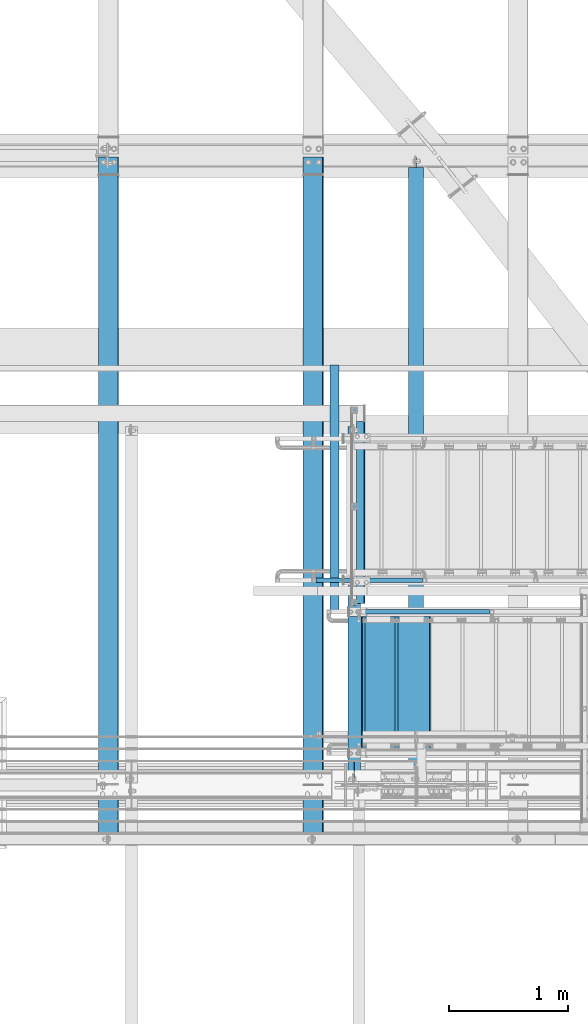
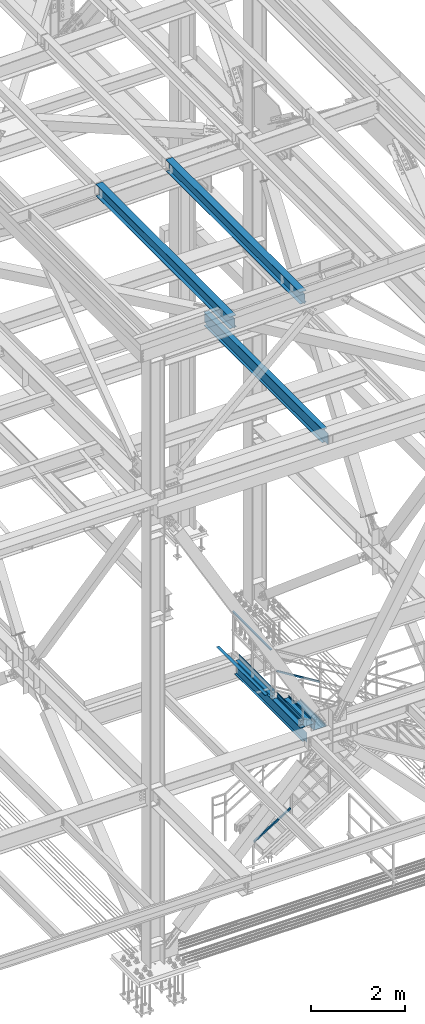
# One storey, part 1944 of 3843: 10 beams, 2 members, 9 elements without a shape of their own.
"""IFC2X3 building model written with IfcOpenShell, lengths in millimetres."""

from ifc_helpers import new_model, si_unit, frame, origin_with_axes, place, context, subcontext, project, spatial, faceted_brep, material, type_object, element, aggregate, save


model = new_model("IFC2X3")

# Units and contexts
model_context = context("Model", 3, precision=1e-05, world=origin_with_axes())
body_context = subcontext(model_context, "Body", "Model", "MODEL_VIEW")
ifc_project = project(units=[si_unit("LENGTHUNIT", "METRE", prefix="MILLI"), si_unit("AREAUNIT", "SQUARE_METRE"), si_unit("VOLUMEUNIT", "CUBIC_METRE"), si_unit("MASSUNIT", "GRAM", prefix="KILO"), si_unit("TIMEUNIT", "SECOND"), si_unit("PLANEANGLEUNIT", "RADIAN"), si_unit("SOLIDANGLEUNIT", "STERADIAN"), si_unit("THERMODYNAMICTEMPERATUREUNIT", "DEGREE_CELSIUS"), si_unit("LUMINOUSINTENSITYUNIT", "LUMEN")], contexts=[model_context])

# Site, building, storey
site_placement = place(None, origin_with_axes())
site = spatial("IfcSite", under=ifc_project, at=site_placement, CompositionType="ELEMENT")
building_placement = place(site_placement, origin_with_axes())
building = spatial("IfcBuilding", under=site, at=building_placement, Name="Undefined", CompositionType="ELEMENT")
storey_placement = place(building_placement, origin_with_axes())
storey = spatial("IfcBuildingStorey", under=building, at=storey_placement, Name="Undefined", CompositionType="ELEMENT", Elevation=0.0)

# Assembly, beam
assembly_1_placement = place(storey_placement, origin_with_axes())
assembly_1 = element("IfcElementAssembly", 1, at=assembly_1_placement, inside=storey, Name="RAIL", AssemblyPlace="NOTDEFINED", PredefinedType="RIGID_FRAME")
ifc_material_1 = material()
beam_type_1 = type_object("IfcBeamType", Name="HSS1-1/2X1-1/2X1/4", PredefinedType="NOTDEFINED")
beam_1_placement = place(assembly_1_placement, frame((80810.1, 16516.35, 36017.2), z_axis=(0.0, 0.0, -1.0), x_axis=(0.0, 1.0, 0.0)))
beam_1 = element("IfcBeam", 2, at=beam_1_placement, type_object=beam_type_1, material=ifc_material_1, Name="RAIL", ObjectType="HSS1-1/2X1-1/2X1/4", context=body_context, shape_type="Brep", body=[
    faceted_brep([(6.34999999999854, 12.6999993299978, -12.6999993299978), (6.34999999999854, -12.6999993299978, -12.6999993299978), (1657.34999933, -12.6999993299978, -12.6999993299978), (1657.34999933, 12.6999993299978, -12.6999993299978), (31.7500007135677, -12.6999993300014, 12.6999993299978), (1631.95000067, -12.6999993299978, 12.6999993299978), (31.7500007135677, 12.6999993300014, 12.6999993299978), (1631.95000067, 12.6999993299978, 12.6999993299978), (0.0, 19.0500000000029, -19.0499999999993), (38.0999984699883, 19.0499992350015, 19.0499992350015), (1625.600000765, 19.0499992349942, 19.0499992350015), (1663.699999235, 19.0499992349942, -19.0499992350015), (38.0999984699883, -19.0499992350015, 19.0499992350015), (1625.600000765, -19.0499992349942, 19.0499992350015), (0.0, -19.0499992350015, -19.0499992350015), (1663.699999235, -19.0499992349942, -19.0499992350015)], [[[0, 1, 2, 3]], [[1, 4, 5, 2]], [[4, 6, 7, 5]], [[6, 0, 3, 7]], [[8, 9, 10, 11]], [[9, 12, 13, 10]], [[12, 14, 15, 13]], [[14, 8, 11, 15]], [[13, 15, 11, 10], [5, 7, 3, 2]], [[14, 12, 9, 8], [6, 4, 1, 0]]]),
])
aggregate(assembly_1, [beam_1])

# Assembly, member
assembly_2_placement = place(storey_placement, origin_with_axes())
assembly_2 = element("IfcElementAssembly", 3, at=assembly_2_placement, inside=storey, Name="RAIL", AssemblyPlace="NOTDEFINED", PredefinedType="RIGID_FRAME")
member_type = type_object("IfcMemberType", Name="HSS1-1/2X1-1/2X1/4", PredefinedType="NOTDEFINED")
member_1_placement = place(assembly_2_placement, frame((81970.0333333517, 16459.2, 34824.7025638998), z_axis=(0.524097425775922, 0.0, 0.851658316635875), x_axis=(-0.851658316635873, 0.0, 0.524097425775925)))
member_1 = element("IfcMember", 4, at=member_1_placement, type_object=member_type, material=ifc_material_1, Name="RAIL", ObjectType="HSS1-1/2X1-1/2X1/4", context=body_context, shape_type="Brep", body=[
    faceted_brep([(14.5527402998268, 12.6999993300014, -12.6999993299833), (14.5527402998268, -12.6999993300014, -12.6999993299833), (1253.99107977215, -12.6999993300014, -12.6999993293284), (1253.99107977215, 12.6999993300014, -12.6999993293284), (30.1835087105574, -12.6999993300014, 12.6999993299978), (1261.18035103604, -12.6999993300014, 12.6999993306526), (30.1835087105574, 12.6999993300014, 12.6999993299978), (1261.18035103604, 12.6999993300014, 12.6999993306526), (10.6450480494532, 19.0499992350015, -19.0499992349796), (34.091200960931, 19.0499992350015, 19.0499992349942), (1262.97766891996, 19.0499992350015, 19.049999235649), (1252.19376188824, 19.0499992350015, -19.0499992343248), (34.091200960931, -19.0499992350015, 19.0499992349942), (1262.97766891996, -19.0499992350015, 19.049999235649), (10.6450480494532, -19.0499992350015, -19.0499992349796), (1252.19376188824, -19.0499992350015, -19.0499992343248)], [[[0, 1, 2, 3]], [[1, 4, 5, 2]], [[4, 6, 7, 5]], [[6, 0, 3, 7]], [[8, 9, 10, 11]], [[9, 12, 13, 10]], [[12, 14, 15, 13]], [[14, 8, 11, 15]], [[13, 15, 11, 10], [5, 7, 3, 2]], [[14, 12, 9, 8], [6, 4, 1, 0]]]),
])
aggregate(assembly_2, [member_1])

assembly_3_placement = place(storey_placement, origin_with_axes())
assembly_3 = element("IfcElementAssembly", 5, at=assembly_3_placement, inside=storey, Name="RAIL", AssemblyPlace="NOTDEFINED", PredefinedType="RIGID_FRAME")
member_2_placement = place(assembly_3_placement, frame((80467.2000000039, 16725.9, 31013.4000000058), z_axis=(-0.524097425775922, 0.0, 0.851658316635875), x_axis=(0.851658316635872, 0.0, 0.524097425775926)))
member_2 = element("IfcMember", 6, at=member_2_placement, type_object=member_type, material=ifc_material_1, Name="RAIL", ObjectType="HSS1-1/2X1-1/2X1/4", context=body_context, shape_type="Brep", body=[
    faceted_brep([(1089.12111513855, -19.0499999999993, 19.0499992355581), (1065.67496222707, -19.0499992350015, -19.0499992344157), (1065.67496222707, 19.0499992350015, -19.0499992344157), (1089.12111513855, 19.0499992350015, 19.0499992355581), (1085.21342288818, -12.6999993300014, 12.6999993305617), (1085.21342288818, 12.6999993300014, 12.6999993305617), (1069.58265447745, 12.6999993300014, -12.6999993294194), (1069.58265447745, -12.6999993300014, -12.6999993294194), (10.6450480494532, 19.0499992350015, -19.0499992349796), (34.091200960931, 19.0499992350015, 19.0499992349942), (34.091200960931, -19.0499992350015, 19.0499992349942), (10.6450480494532, -19.0499992350015, -19.0499992349796), (30.1835087105574, 12.6999993300014, 12.6999993299978), (30.1835087105574, -12.6999993300014, 12.6999993299978), (14.5527402998268, -12.6999993300014, -12.6999993299833), (14.5527402998268, 12.6999993300014, -12.6999993299833)], [[[0, 1, 2, 3], [4, 5, 6, 7]], [[8, 9, 3, 2]], [[9, 10, 0, 3]], [[10, 11, 1, 0]], [[11, 8, 2, 1]], [[11, 10, 9, 8], [12, 13, 14, 15]], [[14, 13, 4, 7]], [[15, 14, 7, 6]], [[12, 15, 6, 5]], [[13, 12, 5, 4]]]),
])
aggregate(assembly_3, [member_2])

# Assembly, beam
assembly_4_placement = place(storey_placement, origin_with_axes())
assembly_4 = element("IfcElementAssembly", 7, at=assembly_4_placement, inside=storey, Name="ref.", AssemblyPlace="NOTDEFINED", PredefinedType="RIGID_FRAME")
ifc_material_2 = material(Name="STEEL/Steel_Undefined")
beam_type_2 = type_object("IfcBeamType", PredefinedType="NOTDEFINED")
beam_2_placement = place(assembly_4_placement, frame((80645.0, 18542.0, 34947.225), z_axis=(1.0, 0.0, 0.0), x_axis=(0.0, -1.0, 0.0)))
beam_2 = element("IfcBeam", 8, at=beam_2_placement, type_object=beam_type_2, material=ifc_material_2, Name="ref.", context=body_context, shape_type="Brep", body=[
    faceted_brep([(0.0, 3.17500000000291, -38.0999999999985), (0.0, 3.17500000000291, 38.0999999999985), (2082.8, 3.17500000000291, 38.0999999999985), (2082.8, 3.17500000000291, -38.0999999999985), (0.0, -3.17500000000291, 38.0999999999985), (2082.8, -3.17500000000291, 38.0999999999985), (0.0, -3.17500000000291, -38.0999999999985), (2082.8, -3.17500000000291, -38.0999999999985)], [[[0, 1, 2, 3]], [[1, 4, 5, 2]], [[4, 6, 7, 5]], [[6, 0, 3, 7]], [[5, 7, 3, 2]], [[6, 4, 1, 0]]]),
])
aggregate(assembly_4, [beam_2])

# Assembly, beams
assembly_5_placement = place(storey_placement, origin_with_axes())
assembly_5 = element("IfcElementAssembly", 9, at=assembly_5_placement, inside=storey, Name="STAIR", AssemblyPlace="NOTDEFINED", PredefinedType="RIGID_FRAME")
ifc_material_3 = material(Name="STEEL/ASTM A1011")
beam_type_3 = type_object("IfcBeamType", PredefinedType="NOTDEFINED")
beam_3_placement = place(assembly_5_placement, frame((80873.6000000088, 15862.299999908, 34948.8124999957), z_axis=(0.0, 1.0, 0.0), x_axis=(1.0, 0.0, 0.0)))
beam_3 = element("IfcBeam", 10, at=beam_3_placement, type_object=beam_type_3, material=ifc_material_3, Name="TREAD", context=body_context, shape_type="Brep", body=[
    faceted_brep([(0.0, -1.58750000000146, -558.799999999999), (0.0, -1.58750000000146, 558.799999999999), (0.0, 1.58750000000146, 558.799999999999), (0.0, 1.58750000000146, -558.799999999999), (21.7215083258779, 1.58750000000146, 558.799999999999), (21.7215083258779, 1.58750000000146, -558.799999999999), (25.3999999999942, -1.58750000000146, -558.799999999999), (25.3999999999942, -1.58750000000146, 558.799999999999), (-11.1830371286633, 224.325961538467, 558.799999999999), (-11.1830371286633, 224.325961538467, -558.799999999999), (-7.50454545454704, 221.150961538464, -558.799999999999), (-7.50454545454704, 221.150961538464, 558.799999999999), (293.616962871325, 224.325961538467, 558.799999999999), (293.616962871325, 224.325961538467, -558.799999999999), (290.876539379024, 221.150961538464, -558.799999999999), (290.876539379024, 221.150961538464, 558.799999999999), (299.585432747743, 183.924011605752, 558.799999999999), (299.585432747743, 183.924011605752, -558.799999999999), (296.444520385252, 183.460013188564, 558.799999999999), (296.444520385252, 183.460013188564, -558.799999999999)], [[[0, 1, 2, 3]], [[3, 2, 4, 5]], [[1, 0, 6, 7]], [[5, 4, 8, 9]], [[7, 6, 10, 11]], [[9, 8, 12, 13]], [[11, 10, 14, 15]], [[13, 12, 16, 17]], [[12, 8, 4, 2, 1, 7, 11, 15, 18, 16]], [[15, 14, 19, 18]], [[14, 10, 6, 0, 3, 5, 9, 13, 17, 19]], [[18, 19, 17, 16]]]),
])
beam_4_placement = place(assembly_5_placement, frame((81152.9999999869, 15862.300000067, 34776.8740384608), z_axis=(0.0, 1.0, 0.0), x_axis=(1.0, 0.0, 0.0)))
beam_4 = element("IfcBeam", 11, at=beam_4_placement, type_object=beam_type_3, material=ifc_material_3, Name="TREAD", context=body_context, shape_type="Brep", body=[
    faceted_brep([(0.0, -1.58750000000146, -558.799999999999), (0.0, -1.58750000000146, 558.799999999999), (0.0, 1.58750000000146, 558.799999999999), (0.0, 1.58750000000146, -558.799999999999), (21.7215083258779, 1.58750000000146, 558.799999999999), (21.7215083258779, 1.58750000000146, -558.799999999999), (25.3999999999942, -1.58750000000146, -558.799999999999), (25.3999999999942, -1.58750000000146, 558.799999999999), (-11.1830371286633, 224.325961538467, 558.799999999999), (-11.1830371286633, 224.325961538467, -558.799999999999), (-7.50454545454704, 221.150961538464, -558.799999999999), (-7.50454545454704, 221.150961538464, 558.799999999999), (293.616962871325, 224.325961538467, 558.799999999999), (293.616962871325, 224.325961538467, -558.799999999999), (290.876539379024, 221.150961538464, -558.799999999999), (290.876539379024, 221.150961538464, 558.799999999999), (299.585432747743, 183.924011605752, 558.799999999999), (299.585432747743, 183.924011605752, -558.799999999999), (296.444520385252, 183.460013188564, 558.799999999999), (296.444520385252, 183.460013188564, -558.799999999999)], [[[0, 1, 2, 3]], [[3, 2, 4, 5]], [[1, 0, 6, 7]], [[5, 4, 8, 9]], [[7, 6, 10, 11]], [[9, 8, 12, 13]], [[11, 10, 14, 15]], [[13, 12, 16, 17]], [[12, 8, 4, 2, 1, 7, 11, 15, 18, 16]], [[15, 14, 19, 18]], [[14, 10, 6, 0, 3, 5, 9, 13, 17, 19]], [[18, 19, 17, 16]]]),
])

# Assembly, beam
assembly_6_placement = place(storey_placement, origin_with_axes())
assembly_6 = element("IfcElementAssembly", 12, at=assembly_6_placement, inside=storey, Name="BEAM", AssemblyPlace="NOTDEFINED", PredefinedType="RIGID_FRAME")
ifc_material_4 = material(Name="STEEL/A992")
beam_type_4 = type_object("IfcBeamType", Name="W12X26", PredefinedType="NOTDEFINED")
beam_5_placement = place(assembly_6_placement, frame((80463.9092623523, 14490.7000000001, 46502.5139311776), z_axis=(-0.0211520980073474, 0.0, 0.999776269347241), x_axis=(0.0, 1.0, 0.0)))
beam_5 = element("IfcBeam", 13, at=beam_5_placement, type_object=beam_type_4, material=ifc_material_4, Name="BEAM", ObjectType="W12X26", context=body_context, shape_type="Brep", body=[
    faceted_brep([(20.6374999998825, -3.17500000016298, -130.175000008305), (20.6374999998825, 3.1749999998865, -130.175000008305), (77.7875001906159, 3.1749999998865, -130.175000008334), (77.7875001906159, -3.17500000016298, -130.175000008334), (82.6475797086623, 3.1749999998865, -131.141729930918), (82.6475797086623, -3.17500000014843, -131.141729930918), (86.767756176816, 3.17499999987194, -133.894743831384), (86.767756176816, -3.17500000014843, -133.894743831377), (89.5207700772935, 3.17499999987194, -138.014920299524), (89.5207700772935, -3.17500000014843, -138.014920299516), (90.487499999881, -3.17500000014843, -142.874999817534), (90.487499999881, 3.17499999987194, -142.874999817541), (90.487499999881, 3.17499999987194, -146.049999999763), (90.487499999881, 82.5500000003231, -146.049999999828), (90.487499999881, 82.5500000003085, -155.574999999815), (90.487499999881, -82.5500000006286, -155.57499999967), (90.487499999881, -82.5500000006141, -146.04999999969), (90.487499999881, -3.17500000017753, -146.049999999756), (5803.89999999989, -82.5500000003231, 146.049999999843), (5803.89999999989, -82.5500000003085, 155.57499999983), (90.487499999881, -82.5500000003085, 155.574980215941), (90.487499999881, -82.5500000003231, 146.049999999843), (5803.89999999989, 82.5500000006141, 155.574999999684), (90.487499999881, 82.5500000006141, 155.574999999684), (5803.89999999989, 82.5500000006141, 146.049999999705), (90.487499999881, 82.5500000006141, 146.049999999705), (5803.89999999989, 3.17500000016298, 146.04999999977), (90.487499999881, 3.17500000016298, 146.04999999977), (77.7875001906159, -3.1749999998865, 130.174999990406), (77.7875001906159, 3.17500000014843, 130.174999990399), (20.6374999998825, 3.17500000014843, 130.174999990428), (20.6374999998825, -3.1749999998865, 130.174999990435), (82.6475797086623, -3.1749999998865, 131.14172991299), (82.6475797086623, 3.17500000013388, 131.14172991299), (86.767756176816, -3.1749999998865, 133.894743813456), (86.767756176816, 3.17500000014843, 133.894743813449), (89.5207700772935, -3.1749999998865, 138.014920281596), (89.5207700772935, 3.17500000016298, 138.014920281588), (90.487499999881, -3.1749999998865, 142.874999799613), (90.487499999881, 3.17500000016298, 142.874999799598), (90.487499999881, -3.1749999998865, 146.04999999977), (5803.89999999989, -3.1749999998865, 146.04999999977), (5803.89999999989, 3.17499999987194, -146.049999999763), (5803.89999999989, -3.17500000017753, -146.049999999756), (5803.89999999989, -82.5500000006141, -146.04999999969), (5803.89999999989, -82.5500000006286, -155.57499999967), (5803.89999999989, 82.5500000003085, -155.574999999815), (5803.89999999989, 82.5500000003231, -146.049999999828), (20.6374999998825, 3.1749999998865, -113.125000025924), (20.6374999998825, 3.17500000013388, 117.474999970342)], [[[0, 1, 2, 3]], [[3, 2, 4, 5]], [[5, 4, 6, 7]], [[7, 6, 8, 9]], [[10, 11, 12, 13, 14, 15, 16, 17]], [[9, 8, 11, 10]], [[18, 19, 20, 21]], [[19, 22, 23, 20]], [[22, 24, 25, 23]], [[24, 26, 27, 25]], [[28, 29, 30, 31]], [[32, 33, 29, 28]], [[34, 35, 33, 32]], [[36, 37, 35, 34]], [[38, 39, 37, 36]], [[20, 23, 25, 27, 39, 38, 40, 21]], [[41, 18, 21, 40]], [[42, 26, 24, 22, 19, 18, 41, 43, 44, 45, 46, 47]], [[44, 43, 17, 16]], [[45, 44, 16, 15]], [[46, 45, 15, 14]], [[47, 46, 14, 13]], [[42, 47, 13, 12]], [[6, 4, 2, 1, 48, 49, 30, 29, 33, 35, 37, 39, 27, 26, 42, 12, 11, 8]], [[31, 30, 49, 48, 1, 0]], [[43, 41, 40, 38, 36, 34, 32, 28, 31, 0, 3, 5, 7, 9, 10, 17]]]),
])
aggregate(assembly_6, [beam_5])

assembly_7_placement = place(storey_placement, origin_with_axes())
assembly_7 = element("IfcElementAssembly", 14, at=assembly_7_placement, inside=storey, Name="BEAM", AssemblyPlace="NOTDEFINED", PredefinedType="RIGID_FRAME")
beam_6_placement = place(assembly_7_placement, frame((78736.7092623524, 14490.7000000001, 46465.9718519174), z_axis=(-0.0211520980073474, 0.0, 0.999776269347241), x_axis=(0.0, 1.0, 0.0)))
beam_6 = element("IfcBeam", 15, at=beam_6_placement, type_object=beam_type_4, material=ifc_material_4, Name="BEAM", ObjectType="W12X26", context=body_context, shape_type="Brep", body=[
    faceted_brep([(20.6374999998825, -3.17500000016298, -130.175000008305), (20.6374999998825, 3.1749999998865, -130.175000008305), (77.7875001906159, 3.1749999998865, -130.175000008334), (77.7875001906159, -3.17500000016298, -130.175000008334), (82.6475797086623, 3.1749999998865, -131.141729930918), (82.6475797086623, -3.17500000014843, -131.141729930918), (86.767756176816, 3.17499999987194, -133.894743831384), (86.767756176816, -3.17500000014843, -133.894743831377), (89.5207700772935, 3.17499999987194, -138.014920299524), (89.5207700772935, -3.17500000014843, -138.014920299516), (90.487499999881, -3.17500000014843, -142.874999817534), (90.487499999881, 3.17499999987194, -142.874999817541), (90.487499999881, 3.17499999987194, -146.049999999763), (90.487499999881, 82.5500000003231, -146.049999999828), (90.487499999881, 82.5500000003085, -155.574999999815), (90.487499999881, -82.5500000006286, -155.57499999967), (90.487499999881, -82.5500000006141, -146.04999999969), (90.487499999881, -3.17500000017753, -146.049999999756), (5803.89999999989, -82.5500000003231, 146.049999999843), (5803.89999999989, -82.5500000003085, 155.57499999983), (90.487499999881, -82.5500000003085, 155.574980215941), (90.487499999881, -82.5500000003231, 146.049999999843), (5803.89999999989, 82.5500000006141, 155.574999999684), (90.487499999881, 82.5500000006141, 155.574999999684), (5803.89999999989, 82.5500000006141, 146.049999999705), (90.487499999881, 82.5500000006141, 146.049999999705), (5803.89999999989, 3.17500000016298, 146.04999999977), (90.487499999881, 3.17500000016298, 146.04999999977), (77.7875001906159, -3.1749999998865, 130.174999990406), (77.7875001906159, 3.17500000014843, 130.174999990399), (20.6374999998825, 3.17500000014843, 130.174999990428), (20.6374999998825, -3.1749999998865, 130.174999990435), (82.6475797086623, -3.1749999998865, 131.14172991299), (82.6475797086623, 3.17500000013388, 131.14172991299), (86.767756176816, -3.1749999998865, 133.894743813456), (86.767756176816, 3.17500000014843, 133.894743813449), (89.5207700772935, -3.1749999998865, 138.014920281596), (89.5207700772935, 3.17500000016298, 138.014920281588), (90.487499999881, -3.1749999998865, 142.874999799613), (90.487499999881, 3.17500000016298, 142.874999799598), (90.487499999881, -3.1749999998865, 146.04999999977), (5803.89999999989, -3.1749999998865, 146.04999999977), (5803.89999999989, 3.17499999987194, -146.049999999763), (5803.89999999989, -3.17500000017753, -146.049999999756), (5803.89999999989, -82.5500000006141, -146.04999999969), (5803.89999999989, -82.5500000006286, -155.57499999967), (5803.89999999989, 82.5500000003085, -155.574999999815), (5803.89999999989, 82.5500000003231, -146.049999999828), (20.6374999998825, 3.1749999998865, -113.125000025924), (20.6374999998825, 3.17500000013388, 117.474999970342)], [[[0, 1, 2, 3]], [[3, 2, 4, 5]], [[5, 4, 6, 7]], [[7, 6, 8, 9]], [[10, 11, 12, 13, 14, 15, 16, 17]], [[9, 8, 11, 10]], [[18, 19, 20, 21]], [[19, 22, 23, 20]], [[22, 24, 25, 23]], [[24, 26, 27, 25]], [[28, 29, 30, 31]], [[32, 33, 29, 28]], [[34, 35, 33, 32]], [[36, 37, 35, 34]], [[38, 39, 37, 36]], [[20, 23, 25, 27, 39, 38, 40, 21]], [[41, 18, 21, 40]], [[42, 26, 24, 22, 19, 18, 41, 43, 44, 45, 46, 47]], [[44, 43, 17, 16]], [[45, 44, 16, 15]], [[46, 45, 15, 14]], [[47, 46, 14, 13]], [[42, 47, 13, 12]], [[6, 4, 2, 1, 48, 49, 30, 29, 33, 35, 37, 39, 27, 26, 42, 12, 11, 8]], [[31, 30, 49, 48, 1, 0]], [[43, 41, 40, 38, 36, 34, 32, 28, 31, 0, 3, 5, 7, 9, 10, 17]]]),
])
aggregate(assembly_7, [beam_6])

# Beam
beam_type_5 = type_object("IfcBeamType", PredefinedType="NOTDEFINED")
beam_7_placement = place(assembly_5_placement, frame((80759.30000002, 15862.2999999039, 34812.2874999957), z_axis=(0.0, 1.0, 0.0), x_axis=(1.0, 0.0, 0.0)))
beam_7 = element("IfcBeam", 16, at=beam_7_placement, type_object=beam_type_5, material=ifc_material_3, Name="TREAD", context=body_context, shape_type="Brep", body=[
    faceted_brep([(0.0, -1.58750000000146, -558.799999999999), (0.0, -1.58750000000146, 558.799999999999), (0.0, 1.58750000000146, 558.799999999999), (0.0, 1.58750000000146, -558.799999999999), (115.347451987429, 1.58750000000146, 558.799999999999), (115.347451987429, 1.58750000000146, -558.799999999999), (112.643584814185, -1.58750000000146, -558.799999999999), (112.643584814185, -1.58750000000146, 558.799999999999), (121.346043638841, -35.5978063759467, 558.799999999999), (121.346043638841, -35.5978063759467, -558.799999999999), (118.2115658236, -36.1034483696931, 558.799999999999), (118.2115658236, -36.1034483696931, -558.799999999999)], [[[0, 1, 2, 3]], [[3, 2, 4, 5]], [[1, 0, 6, 7]], [[5, 4, 8, 9]], [[4, 2, 1, 7, 10, 8]], [[7, 6, 11, 10]], [[6, 0, 3, 5, 9, 11]], [[10, 11, 9, 8]]]),
])

aggregate(assembly_5, [beam_7, beam_3, beam_4])

# Assembly, beams
assembly_8_placement = place(storey_placement, origin_with_axes())
assembly_8 = element("IfcElementAssembly", 17, at=assembly_8_placement, inside=storey, Name="BEAM", AssemblyPlace="NOTDEFINED", PredefinedType="RIGID_FRAME")
beam_type_6 = type_object("IfcBeamType", Name="W12X19", PredefinedType="NOTDEFINED")
beam_8_placement = place(assembly_8_placement, frame((80810.1, 14998.7, 34656.7125), z_axis=(0.0, 0.0, 1.0), x_axis=(0.0, 1.0, 0.0)))
beam_8 = element("IfcBeam", 18, at=beam_8_placement, type_object=beam_type_6, material=ifc_material_4, Name="BEAM", ObjectType="W12X19", context=body_context, shape_type="Brep", body=[
    faceted_brep([(18.2562500000004, -3.17500000000291, -128.587500000001), (18.2562500000004, 3.17500000000291, -128.587500000001), (107.156248664856, 3.17500000000291, -128.587500000001), (107.156248664856, -3.17500000000291, -128.587500000001), (112.016328182903, 3.17500000000291, -129.554229922593), (112.016328182903, -3.17500000000291, -129.554229922593), (116.136504651056, 3.17500000000291, -132.307243823067), (116.136504651056, -3.17500000000291, -132.307243823067), (118.889518551534, 3.17500000000291, -136.42742029122), (118.889518551534, -3.17500000000291, -136.42742029122), (119.856248474121, -3.17500000000291, -141.287499809267), (119.856248474121, 3.17500000000291, -141.287499809267), (119.856248474121, 3.17500000000291, -144.462500000001), (119.856248474121, 50.8000000000029, -144.462500000001), (119.856248474121, 50.8000000000029, -153.987500000003), (119.856248474121, -50.8000000000029, -153.987500000003), (119.856248474121, -50.8000000000029, -144.462500000001), (119.856248474121, -3.17500000000291, -144.462500000001), (202.406250000013, 3.17500000000291, 144.462500000001), (202.406250000013, 50.8000000000029, 144.462500000001), (2948.78124999999, 50.8000000000029, 144.462500000001), (2948.78124999999, 3.17500000000291, 144.462500000001), (189.706250190748, -3.17500000000291, 122.237500000003), (189.706250190748, 3.17500000000291, 122.237500000003), (18.2562500000058, 3.17499999999927, 122.23750000001), (18.2562500000058, -3.17499999999927, 122.23750000001), (194.566329708794, -3.17500000000291, 123.204229922594), (194.566329708794, 3.17500000000291, 123.204229922594), (198.686506176948, -3.17500000000291, 125.957243823068), (198.686506176948, 3.17500000000291, 125.957243823068), (201.439520077425, -3.17500000000291, 130.077420291222), (201.439520077425, 3.17500000000291, 130.077420291222), (202.406250000013, -3.17500000000291, 134.937499809268), (202.406250000013, 3.17500000000291, 134.937499809268), (202.406250000013, 50.8000000000029, 153.987500000003), (202.406250000013, -50.8000000000029, 153.987500000003), (2948.78124999999, -50.8000000000029, 153.987500000003), (2948.78124999999, 50.8000000000029, 153.987500000003), (202.406250000013, -50.8000000000029, 144.462500000001), (2948.78124999999, -50.8000000000029, 144.462500000001), (202.406250000013, -3.17500000000291, 144.462500000001), (2948.78124999999, -3.17500000000291, 144.462500000001), (2948.78125047311, -3.17500000000291, 141.027501487726), (2948.78125047311, 3.17500000000291, 141.027501487726), (2949.7479803957, -3.17500000000291, 136.16742196968), (2949.7479803957, 3.17500000000291, 136.16742196968), (2952.50099429617, -3.17500000000291, 132.047245501526), (2952.50099429617, 3.17500000000291, 132.047245501526), (2956.62117076433, -3.17500000000291, 129.294231601052), (2956.62117076433, 3.17500000000291, 129.294231601052), (2961.48125028237, -3.17500000000291, 128.327501678461), (2961.48125028237, 3.17500000000291, 128.327501678461), (3024.98125, -3.17500000000291, 128.327501678461), (3024.98125, 3.17500000000291, 128.327501678461), (3024.98125, -3.17500000000291, -144.462500000001), (3024.98125, -50.8000000000029, -144.462500000001), (3024.98125, -50.8000000000029, -153.987500000003), (3024.98125, 50.8000000000029, -153.987500000003), (3024.98125, 50.8000000000029, -144.462500000001), (3024.98125, 3.17500000000291, -144.462500000001), (18.2562500000004, 3.17500000000291, -127.412499999999), (18.2562500000004, 3.17500000000291, 103.1875)], [[[0, 1, 2, 3]], [[3, 2, 4, 5]], [[5, 4, 6, 7]], [[7, 6, 8, 9]], [[10, 11, 12, 13, 14, 15, 16, 17]], [[9, 8, 11, 10]], [[18, 19, 20, 21]], [[22, 23, 24, 25]], [[26, 27, 23, 22]], [[28, 29, 27, 26]], [[30, 31, 29, 28]], [[32, 33, 31, 30]], [[34, 35, 36, 37]], [[35, 38, 39, 36]], [[38, 40, 41, 39]], [[35, 34, 19, 18, 33, 32, 40, 38]], [[19, 34, 37, 20]], [[36, 39, 41, 42, 43, 21, 20, 37]], [[44, 45, 43, 42]], [[46, 47, 45, 44]], [[48, 49, 47, 46]], [[50, 51, 49, 48]], [[52, 53, 51, 50]], [[54, 55, 56, 57, 58, 59, 53, 52]], [[55, 54, 17, 16]], [[56, 55, 16, 15]], [[57, 56, 15, 14]], [[58, 57, 14, 13]], [[59, 58, 13, 12]], [[6, 4, 2, 1, 60, 61, 24, 23, 27, 29, 31, 33, 18, 21, 43, 45, 47, 49, 51, 53, 59, 12, 11, 8]], [[25, 24, 61, 60, 1, 0]], [[54, 52, 50, 48, 46, 44, 42, 41, 40, 32, 30, 28, 26, 22, 25, 0, 3, 5, 7, 9, 10, 17]]]),
])
ifc_material_5 = material(Name="STEEL/A36")
beam_type_7 = type_object("IfcBeamType", PredefinedType="NOTDEFINED")
beam_9_placement = place(assembly_8_placement, frame((80810.1, 17298.19375, 34813.875), z_axis=(0.0, -1.0, 0.0), x_axis=(1.0, 0.0, 0.0)))
beam_9 = element("IfcBeam", 19, at=beam_9_placement, type_object=beam_type_7, material=ifc_material_5, Name="BENT_PLATE", context=body_context, shape_type="Brep", body=[
    faceted_brep([(0.0, -3.17500000000291, -766.762500000001), (0.0, -3.17500000000291, 766.762500000001), (0.0, 3.17500000000291, 766.762500000001), (0.0, 3.17500000000291, -766.762500000001), (82.5499999999884, 3.17500000000291, 766.762500000001), (82.5499999999884, 3.17500000000291, -766.762500000001), (88.8999999999942, -3.17500000000291, -766.762500000001), (88.8999999999942, -3.17500000000291, 766.762500000001), (82.5499999999884, 136.524999999994, 766.762500000001), (82.5499999999884, 136.524999999994, -766.762500000001), (88.8999999999942, 136.524999999994, 766.762500000001), (88.8999999999942, 136.524999999994, -766.762500000001)], [[[0, 1, 2, 3]], [[3, 2, 4, 5]], [[1, 0, 6, 7]], [[5, 4, 8, 9]], [[4, 2, 1, 7, 10, 8]], [[7, 6, 11, 10]], [[6, 0, 3, 5, 9, 11]], [[10, 11, 9, 8]]]),
])
aggregate(assembly_8, [beam_9, beam_8])

# Assembly, beam
assembly_9_placement = place(storey_placement, origin_with_axes())
assembly_9 = element("IfcElementAssembly", 20, at=assembly_9_placement, inside=storey, Name="BEAM", AssemblyPlace="NOTDEFINED", PredefinedType="RIGID_FRAME")
beam_type_8 = type_object("IfcBeamType", Name="W14X26", PredefinedType="NOTDEFINED")
beam_10_placement = place(assembly_9_placement, frame((81330.8, 14998.7, 42246.55), z_axis=(0.0, 0.0, 1.0), x_axis=(0.0, 1.0, 0.0)))
beam_10 = element("IfcBeam", 21, at=beam_10_placement, type_object=beam_type_8, material=ifc_material_4, Name="BEAM", ObjectType="W14X26", context=body_context, shape_type="Brep", body=[
    faceted_brep([(5210.175, -3.17500000000291, -165.099999999999), (5210.175, -63.5, -165.099999999999), (5210.175, -63.5, -176.212500000001), (5210.175, 63.5, -176.212500000001), (5210.175, 63.5, -165.099999999999), (5210.175, 3.17500000000291, -165.099999999999), (5210.175, 3.17500000000291, -160.337499809248), (5210.175, -3.17500000000291, -160.337499809248), (5211.14172992259, 3.17500000000291, -155.477420291201), (5211.14172992259, -3.17500000000291, -155.477420291201), (5213.89474382307, 3.17500000000291, -151.357243823048), (5213.89474382307, -3.17500000000291, -151.357243823048), (5218.01492029122, 3.17500000000291, -148.604229922574), (5218.01492029122, -3.17500000000291, -148.604229922574), (5222.87499980927, 3.17500000000291, -147.637499999983), (5222.87499980927, -3.17500000000291, -147.637499999983), (5291.93125, -3.17500000000291, -147.637499999983), (5291.93125, 3.17500000000291, -147.637499999983), (5210.175, 63.5, 165.099999999999), (5210.175, 3.17500000000291, 165.099999999999), (171.450000000001, 3.17500000000291, 165.099999999999), (171.450000000001, 63.5, 165.099999999999), (171.450000000001, -3.17500000000291, -163.512499809258), (171.450000000001, 3.17500000000291, -163.512499809258), (171.450000000001, 3.17500000000291, -165.099999999999), (171.450000000001, 63.5, -165.099999999999), (171.450000000001, 63.5, -176.212500000001), (171.450000000001, -63.5, -176.212500000001), (171.450000000001, -63.5, -165.099999999999), (171.450000000001, -3.17500000000291, -165.099999999999), (170.483270077413, -3.17500000000291, -158.652420291211), (170.483270077413, 3.17500000000291, -158.652420291211), (167.730256176936, -3.17500000000291, -154.532243823058), (167.730256176936, 3.17500000000291, -154.532243823058), (163.610079708782, -3.17500000000291, -151.779229922584), (163.610079708782, 3.17500000000291, -151.779229922584), (158.750000190736, -3.17500000000291, -150.812499999993), (158.750000190736, 3.17500000000291, -150.812499999993), (19.0500000000011, -3.17500000000291, -150.812499999993), (19.0500000000011, 3.17500000000291, -150.812499999993), (19.0500000000011, -3.17500000000291, 138.11250000001), (19.0500000000011, 3.17500000000291, 138.11250000001), (158.750000190736, -3.17500000000291, 138.11250000001), (158.750000190736, 3.17500000000291, 138.11250000001), (163.610079708782, -3.17500000000291, 139.079229922601), (163.610079708782, 3.17500000000291, 139.079229922601), (167.730256176936, -3.17500000000291, 141.832243823075), (167.730256176936, 3.17500000000291, 141.832243823075), (170.483270077413, -3.17500000000291, 145.952420291229), (170.483270077413, 3.17500000000291, 145.952420291229), (171.450000000001, -3.17500000000291, 150.812499809275), (171.450000000001, 3.17500000000291, 150.812499809275), (5210.175, -63.5, 176.212500000001), (5210.175, 63.5, 176.212500000001), (171.450000000001, 63.5, 176.212500000001), (171.450000000001, -63.5, 176.212500000001), (5210.175, -63.5, 165.099999999999), (171.450000000001, -63.5, 165.099999999999), (5210.175, -3.17500000000291, 165.099999999999), (171.450000000001, -3.17500000000291, 165.099999999999), (5210.175, -3.17500000000291, 160.337499809277), (5210.175, 3.17500000000291, 160.337499809277), (5211.14172992259, -3.17500000000291, 155.47742029123), (5211.14172992259, 3.17500000000291, 155.47742029123), (5213.89474382307, -3.17500000000291, 151.357243823077), (5213.89474382307, 3.17500000000291, 151.357243823077), (5218.01492029122, -3.17500000000291, 148.604229922603), (5218.01492029122, 3.17500000000291, 148.604229922603), (5222.87499980927, -3.17500000000291, 147.637500000012), (5222.87499980927, 3.17500000000291, 147.637500000012), (5291.93125, -3.17500000000291, 147.637500000012), (5291.93125, 3.17500000000291, 147.637500000012), (5291.93125, 3.17500000000291, -92.4875000000029), (5291.93125, 3.17500000000291, 138.112500000003)], [[[0, 1, 2, 3, 4, 5, 6, 7]], [[7, 6, 8, 9]], [[9, 8, 10, 11]], [[11, 10, 12, 13]], [[13, 12, 14, 15]], [[16, 15, 14, 17]], [[18, 19, 20, 21]], [[22, 23, 24, 25, 26, 27, 28, 29]], [[30, 31, 23, 22]], [[32, 33, 31, 30]], [[34, 35, 33, 32]], [[36, 37, 35, 34]], [[38, 39, 37, 36]], [[40, 41, 39, 38]], [[42, 43, 41, 40]], [[44, 45, 43, 42]], [[46, 47, 45, 44]], [[48, 49, 47, 46]], [[50, 51, 49, 48]], [[52, 53, 54, 55]], [[56, 52, 55, 57]], [[58, 56, 57, 59]], [[55, 54, 21, 20, 51, 50, 59, 57]], [[53, 18, 21, 54]], [[52, 56, 58, 60, 61, 19, 18, 53]], [[62, 63, 61, 60]], [[64, 65, 63, 62]], [[66, 67, 65, 64]], [[68, 69, 67, 66]], [[70, 71, 69, 68]], [[72, 73, 71, 70, 16, 17]], [[12, 10, 8, 6, 5, 24, 23, 31, 33, 35, 37, 39, 41, 43, 45, 47, 49, 51, 20, 19, 61, 63, 65, 67, 69, 71, 73, 72, 17, 14]], [[25, 24, 5, 4]], [[26, 25, 4, 3]], [[27, 26, 3, 2]], [[28, 27, 2, 1]], [[29, 28, 1, 0]], [[70, 68, 66, 64, 62, 60, 58, 59, 50, 48, 46, 44, 42, 40, 38, 36, 34, 32, 30, 22, 29, 0, 7, 9, 11, 13, 15, 16]]]),
])
aggregate(assembly_9, [beam_10])

save(model, "model.ifc")
